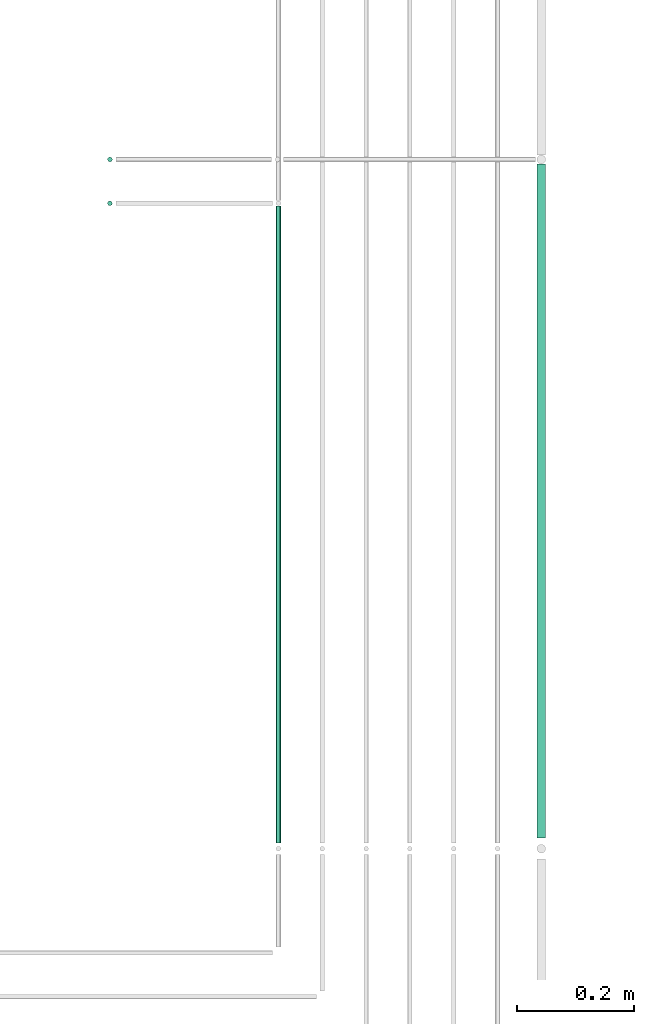
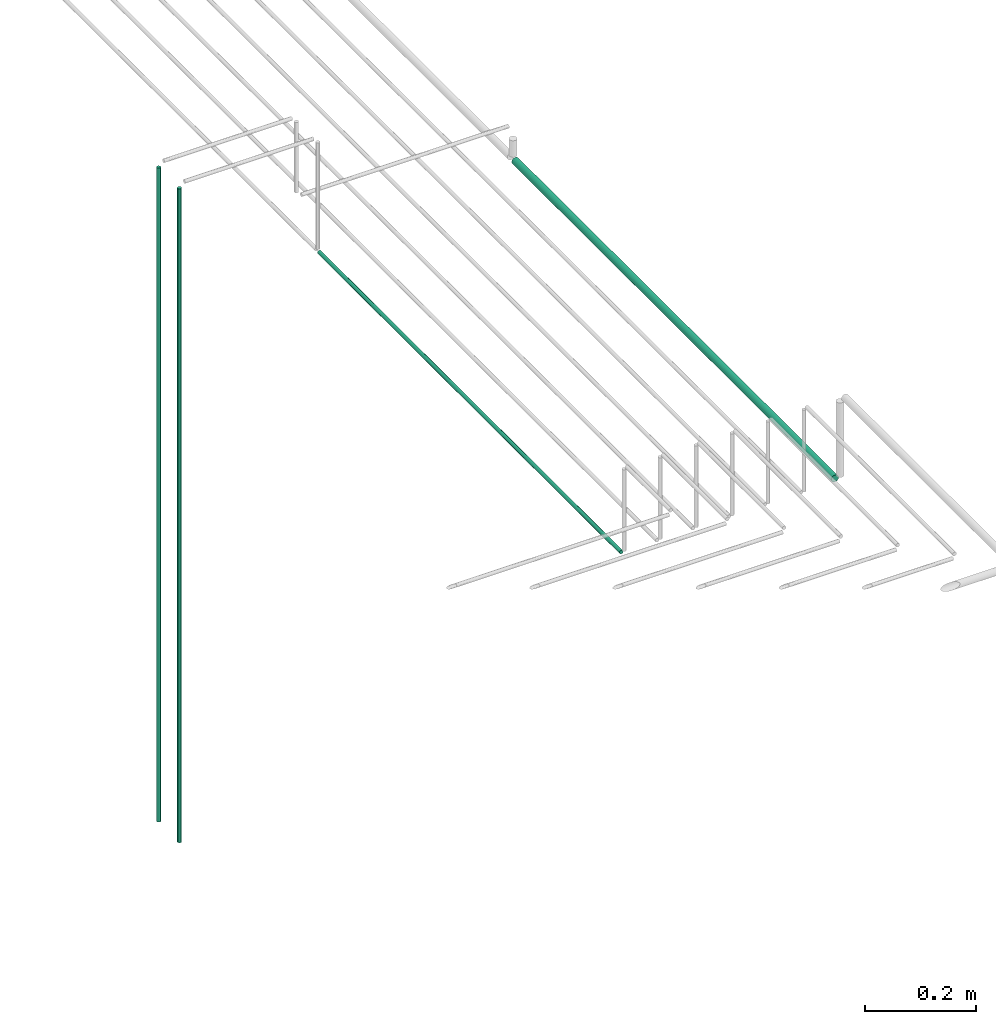
# One storey, part 16 of 89: 4 flow segments.
"""IFC2X3 building model written with IfcOpenShell, lengths in millimetres."""

import ifcopenshell
import ifcopenshell.guid

model = None  # the IFC model being written
_history = None  # IfcOwnerHistory: only IFC2X3 demands one
_inside = {}  # id of a spatial element -> (the spatial element, [elements in it])
_under = {}  # id of a project, library or spatial element -> (it, [spatial elements below it])
_declared = {}  # id of a project -> (the project, [libraries it declares])
_typed = {}  # id of a type object -> (the type object, [elements of that type])
_made_of = {}  # id of a material, layer set ... -> (it, [elements and type objects made of it])


def new_model(schema):
    """Start an empty IFC model of exactly this schema.

    Asked for "IFC4X3", IfcOpenShell would pick the latest addendum, in which some entities
    have other attributes; the version numbers below select the first issue.
    IFC2X3 requires an IfcOwnerHistory on every rooted entity: one is made here for all.
    """
    global model, _history
    if schema == "IFC4X3":
        model = ifcopenshell.file(schema_version=(4, 3, 0, 0))
    else:
        model = ifcopenshell.file(schema=schema)
    _inside.clear()
    _under.clear()
    _declared.clear()
    _typed.clear()
    _made_of.clear()
    _history = None
    if model.schema == "IFC2X3":
        org = make("IfcOrganization", Name="unknown")
        user = make(
            "IfcPersonAndOrganization",
            ThePerson=make("IfcPerson", FamilyName="unknown"),
            TheOrganization=org,
        )
        app = make(
            "IfcApplication",
            ApplicationDeveloper=org,
            Version="unknown",
            ApplicationFullName="unknown",
            ApplicationIdentifier="unknown",
        )
        _history = make(
            "IfcOwnerHistory",
            OwningUser=user,
            OwningApplication=app,
            ChangeAction="ADDED",
            CreationDate=0,
        )
    return model


def make(cls, **values):
    """One entity of the class cls with the attributes given. An attribute that is None is left unset."""
    return model.create_entity(
        cls, **{name: value for name, value in values.items() if value is not None}
    )


def entity(cls, *values):
    """Any entity or typed value of the class cls, its attributes in the order of the schema. None: left unset."""
    e = model.create_entity(cls)
    for i, value in enumerate(values):
        if value is not None:
            e[i] = value
    return e


def rooted(cls, **values):
    """An entity with a GlobalId (a new one), such as an element, a storey or a relation."""
    return make(cls, GlobalId=ifcopenshell.guid.new(), OwnerHistory=_history, **values)


def si_unit(unit_type, name, prefix=None):
    """IfcSIUnit, for example si_unit("LENGTHUNIT", "METRE", prefix="MILLI")."""
    return make("IfcSIUnit", UnitType=unit_type, Prefix=prefix, Name=name)


def converted_unit(unit_type, name, factor, base, dimensions=None, offset=None):
    """IfcConversionBasedUnit, such as the inch: factor (a typed value) times the base unit."""
    return make(
        "IfcConversionBasedUnit"
        if offset is None
        else "IfcConversionBasedUnitWithOffset",
        ConversionOffset=offset,
        Dimensions=None
        if dimensions is None
        else entity("IfcDimensionalExponents", *dimensions),
        UnitType=unit_type,
        Name=name,
        ConversionFactor=make(
            "IfcMeasureWithUnit", ValueComponent=factor, UnitComponent=base
        ),
    )


def derived_unit(unit_type, elements):
    """IfcDerivedUnit: a product of units, each with its exponent."""
    return make(
        "IfcDerivedUnit",
        Elements=[
            make("IfcDerivedUnitElement", Unit=unit, Exponent=power)
            for unit, power in elements
        ],
        UnitType=unit_type,
    )


def assignment(units):
    """IfcUnitAssignment: the units of a project."""
    return None if units is None else make("IfcUnitAssignment", Units=units)


def point(xyz):
    """IfcCartesianPoint."""
    return None if xyz is None else make("IfcCartesianPoint", Coordinates=xyz)


def direction(xyz):
    """IfcDirection."""
    return None if xyz is None else make("IfcDirection", DirectionRatios=xyz)


def frame(location, z_axis=None, x_axis=None):
    """IfcAxis2Placement3D, a coordinate frame: its origin and axes. An axis left out is left unset."""
    return make(
        "IfcAxis2Placement3D",
        Location=point(location),
        Axis=direction(z_axis),
        RefDirection=direction(x_axis),
    )


def frame_2d(location, x_axis=None):
    """IfcAxis2Placement2D, a coordinate frame in the plane: its origin and x axis."""
    return make(
        "IfcAxis2Placement2D", Location=point(location), RefDirection=direction(x_axis)
    )


def origin():
    """The frame at (0, 0, 0) with its axes left unset."""
    return frame((0.0, 0.0, 0.0))


def origin_2d_with_axis():
    """The frame at (0, 0) in the plane with the x axis (1, 0) written out."""
    return frame_2d((0.0, 0.0), x_axis=(1.0, 0.0))


def place(relative_to, where):
    """IfcLocalPlacement: puts the frame where relative to a parent placement (None: the world)."""
    return make(
        "IfcLocalPlacement", PlacementRelTo=relative_to, RelativePlacement=where
    )


def context(
    kind, dimensions, precision=None, world=None, true_north=None, identifier=None
):
    """IfcGeometricRepresentationContext, for example the 3D "Model" context."""
    return make(
        "IfcGeometricRepresentationContext",
        ContextIdentifier=identifier,
        ContextType=kind,
        CoordinateSpaceDimension=dimensions,
        Precision=precision,
        WorldCoordinateSystem=world,
        TrueNorth=true_north,
    )


def subcontext(parent, identifier, kind, view, scale=None):
    """IfcGeometricRepresentationSubContext, for example "Body" below "Model"."""
    return make(
        "IfcGeometricRepresentationSubContext",
        ContextIdentifier=identifier,
        ContextType=kind,
        ParentContext=parent,
        TargetScale=scale,
        TargetView=view,
    )


def project(units=None, contexts=None):
    """IfcProject with its units and contexts."""
    return rooted(
        "IfcProject",
        Name="project",
        RepresentationContexts=contexts,
        UnitsInContext=assignment(units),
    )


def spatial(cls, under=None, at=None, **own):
    """A site, building, storey or space (cls), placed at a placement, below another one or the project."""
    s = rooted(cls, ObjectPlacement=at, **own)
    if under is not None:
        _under.setdefault(under.id(), (under, []))[1].append(s)
    return s


def profile(cls, at=None, kind="AREA", **sizes):
    """A parametric profile (cls). Its sizes go by their IFC names, for example OverallWidth=200.0."""
    return make(cls, ProfileType=kind, Position=at, **sizes)


def circle(**sizes):
    """IfcCircleProfileDef."""
    return profile("IfcCircleProfileDef", **sizes)


def extrude(swept, where, along, depth):
    """IfcExtrudedAreaSolid: the profile swept, set in the frame where, extruded along a direction by depth."""
    return make(
        "IfcExtrudedAreaSolid",
        SweptArea=swept,
        Position=where,
        ExtrudedDirection=direction(along),
        Depth=depth,
    )


def shape(context_of_items, identifier, shape_type, items):
    """IfcShapeRepresentation: the items that make up one representation, for example the "Body"."""
    return make(
        "IfcShapeRepresentation",
        ContextOfItems=context_of_items,
        RepresentationIdentifier=identifier,
        RepresentationType=shape_type,
        Items=items,
    )


def made_of(thing, what):
    """Note that an element or type object is made of a material, layer set ...; save() writes the relation."""
    if what is not None:
        _made_of.setdefault(what.id(), (what, []))[1].append(thing)
    return thing


def type_object(cls, material=None, **own):
    """A type object (cls), such as IfcWallType, which elements share."""
    return made_of(rooted(cls, **own), material)


def element(
    cls,
    number,
    at=None,
    inside=None,
    cuts=None,
    type_object=None,
    material=None,
    context=None,
    identifier="Body",
    shape_type=None,
    held_by="IfcProductDefinitionShape",
    body=None,
    shapes=None,
    **own,
):
    """One element of the class cls, such as IfcWall. Its Tag is "e" and its number.

    at: its placement. inside: the storey or other place that contains it. cuts: it is an
    opening in that element (IfcRelVoidsElement). A single representation is given by context,
    identifier, shape_type and body (its items); several are given by shapes. held_by: the class
    of the entity that holds the representations. save() writes the other relations.
    """
    e = rooted(cls, Tag="e%d" % number, ObjectPlacement=at, **own)
    if body is not None:
        shapes = [shape(context, identifier, shape_type, body)]
    if shapes is not None:
        e.Representation = make(held_by, Representations=shapes)
    if inside is not None:
        _inside.setdefault(inside.id(), (inside, []))[1].append(e)
    if cuts is not None:
        rooted(
            "IfcRelVoidsElement", RelatingBuildingElement=cuts, RelatedOpeningElement=e
        )
    if type_object is not None:
        _typed.setdefault(type_object.id(), (type_object, []))[1].append(e)
    return made_of(e, material)


def aggregate(whole, parts):
    """IfcRelAggregates: a whole, such as a stair, and the parts it consists of."""
    return rooted("IfcRelAggregates", RelatingObject=whole, RelatedObjects=parts)


def save(model, path):
    """Write the relations noted so far, then the file.

    IfcRelAggregates (storeys below a building ...), IfcRelContainedInSpatialStructure (elements
    in a storey), IfcRelDefinesByType, IfcRelAssociatesMaterial and IfcRelDeclares: one each for
    every whole, place, type object, material and project.
    """
    for whole, parts in _under.values():
        aggregate(whole, parts)
    for where, things in _inside.values():
        rooted(
            "IfcRelContainedInSpatialStructure",
            RelatedElements=things,
            RelatingStructure=where,
        )
    for kind, things in _typed.values():
        rooted("IfcRelDefinesByType", RelatedObjects=things, RelatingType=kind)
    for what, things in _made_of.values():
        rooted("IfcRelAssociatesMaterial", RelatedObjects=things, RelatingMaterial=what)
    for by, libraries in _declared.values():
        rooted("IfcRelDeclares", RelatingContext=by, RelatedDefinitions=libraries)
    model.write(path)


model = new_model("IFC2X3")

# Units and contexts
model_context = context("Model", 3, precision=0.01, world=origin(), true_north=direction((6.12303176911189e-17, 1.0)))
body_context = subcontext(model_context, "Body", "Model", "MODEL_VIEW")
ifc_project = project(units=[si_unit("LENGTHUNIT", "METRE", prefix="MILLI"), si_unit("AREAUNIT", "SQUARE_METRE"), si_unit("VOLUMEUNIT", "CUBIC_METRE"), converted_unit("PLANEANGLEUNIT", "DEGREE", entity("IfcRatioMeasure", 0.0174532925199433), si_unit("PLANEANGLEUNIT", "RADIAN"), dimensions=[0, 0, 0, 0, 0, 0, 0]), si_unit("MASSUNIT", "GRAM", prefix="KILO"), derived_unit("MASSDENSITYUNIT", [(si_unit("MASSUNIT", "GRAM", prefix="KILO"), 1), (si_unit("LENGTHUNIT", "METRE"), -3)]), derived_unit("MOMENTOFINERTIAUNIT", [(si_unit("LENGTHUNIT", "METRE"), 4)]), si_unit("TIMEUNIT", "SECOND"), si_unit("FREQUENCYUNIT", "HERTZ"), si_unit("THERMODYNAMICTEMPERATUREUNIT", "DEGREE_CELSIUS"), derived_unit("THERMALTRANSMITTANCEUNIT", [(si_unit("MASSUNIT", "GRAM", prefix="KILO"), 1), (si_unit("THERMODYNAMICTEMPERATUREUNIT", "KELVIN"), -1), (si_unit("TIMEUNIT", "SECOND"), -3)]), derived_unit("VOLUMETRICFLOWRATEUNIT", [(si_unit("LENGTHUNIT", "METRE"), 3), (si_unit("TIMEUNIT", "SECOND"), -1)]), derived_unit("MASSFLOWRATEUNIT", [(si_unit("MASSUNIT", "GRAM", prefix="KILO"), 1), (si_unit("TIMEUNIT", "SECOND"), -1)]), derived_unit("ROTATIONALFREQUENCYUNIT", [(si_unit("TIMEUNIT", "SECOND"), -1)]), si_unit("ELECTRICCURRENTUNIT", "AMPERE"), si_unit("ELECTRICVOLTAGEUNIT", "VOLT"), si_unit("POWERUNIT", "WATT"), si_unit("FORCEUNIT", "NEWTON", prefix="KILO"), si_unit("ILLUMINANCEUNIT", "LUX"), si_unit("LUMINOUSFLUXUNIT", "LUMEN"), si_unit("LUMINOUSINTENSITYUNIT", "CANDELA"), derived_unit("USERDEFINED", [(si_unit("MASSUNIT", "GRAM", prefix="KILO"), -1), (si_unit("LENGTHUNIT", "METRE"), -2), (si_unit("TIMEUNIT", "SECOND"), 3), (si_unit("LUMINOUSFLUXUNIT", "LUMEN"), 1)]), derived_unit("LINEARVELOCITYUNIT", [(si_unit("LENGTHUNIT", "METRE"), 1), (si_unit("TIMEUNIT", "SECOND"), -1)]), si_unit("PRESSUREUNIT", "PASCAL"), derived_unit("USERDEFINED", [(si_unit("LENGTHUNIT", "METRE"), -2), (si_unit("MASSUNIT", "GRAM", prefix="KILO"), 1), (si_unit("TIMEUNIT", "SECOND"), -2)]), derived_unit("LINEARFORCEUNIT", [(si_unit("MASSUNIT", "GRAM", prefix="KILO"), 1), (si_unit("LENGTHUNIT", "METRE"), 1), (si_unit("TIMEUNIT", "SECOND"), -2), (si_unit("LENGTHUNIT", "METRE"), -1)]), derived_unit("PLANARFORCEUNIT", [(si_unit("MASSUNIT", "GRAM", prefix="KILO"), 1), (si_unit("LENGTHUNIT", "METRE"), 1), (si_unit("TIMEUNIT", "SECOND"), -2), (si_unit("LENGTHUNIT", "METRE"), -2)])], contexts=[model_context])

# Site, building, storey
site_placement = place(None, frame((0.0, -0.00077364408347762, 0.0)))
site = spatial("IfcSite", under=ifc_project, at=site_placement, CompositionType="ELEMENT")
building_placement = place(site_placement, origin())
building = spatial("IfcBuilding", under=site, at=building_placement, CompositionType="ELEMENT")
storey_placement = place(building_placement, frame((0.0, 0.0, 24000.0)))
storey = spatial("IfcBuildingStorey", under=building, at=storey_placement, CompositionType="ELEMENT", Elevation=24000.0)

# Flow segments
pipe_segment_type = type_object("IfcPipeSegmentType", PredefinedType="NOTDEFINED")
flow_segment_1_placement = place(storey_placement, frame((66925.8680784348, 2977.64530556803, 1599.29036474498)))
element("IfcFlowSegment", 1, at=flow_segment_1_placement, inside=storey, type_object=pipe_segment_type, context=body_context, shape_type="SweptSolid", body=[
    extrude(circle(Radius=4.0, at=origin_2d_with_axis()), frame((5.59527223591499, 5.59527223591607, 0.0)), (0.0, 0.0, 1.0), 1440.70963525503),
])
flow_segment_2_placement = place(storey_placement, frame((66925.8680784348, 2902.64530556804, 1599.29036474498)))
element("IfcFlowSegment", 2, at=flow_segment_2_placement, inside=storey, type_object=pipe_segment_type, context=body_context, shape_type="SweptSolid", body=[
    extrude(circle(Radius=4.0, at=origin_2d_with_axis()), frame((5.59527223591499, 5.59527223591607, 0.0)), (0.0, 0.0, 1.0), 1440.70963525505),
])
flow_segment_3_placement = place(storey_placement, frame((67660.9049963189, 1821.24057780393, 2790.90472776409)))
element("IfcFlowSegment", 3, at=flow_segment_3_placement, inside=storey, type_object=pipe_segment_type, context=body_context, shape_type="SweptSolid", body=[
    extrude(circle(Radius=7.5, at=origin_2d_with_axis()), frame((9.09527223591419, 0.0, 9.09527223591419), z_axis=(0.0, 1.0, 0.0), x_axis=(-1.0, 0.0, 0.0)), (0.0, 0.0, 1.0), 1154.00000000001),
])
flow_segment_4_placement = place(storey_placement, frame((67214.4049963189, 1813.24057780393, 2794.4047277641)))
element("IfcFlowSegment", 4, at=flow_segment_4_placement, inside=storey, type_object=pipe_segment_type, context=body_context, shape_type="SweptSolid", body=[
    extrude(circle(Radius=4.0, at=origin_2d_with_axis()), frame((5.59527223591499, 0.0, 5.59527223591499), z_axis=(0.0, 1.0, 0.0), x_axis=(-1.0, 0.0, 0.0)), (0.0, 0.0, 1.0), 1090.00000000001),
])

save(model, "model.ifc")
